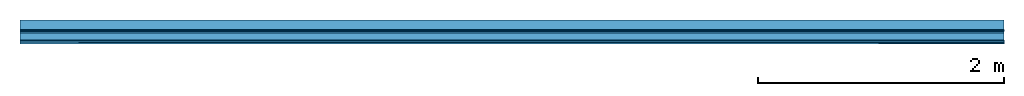
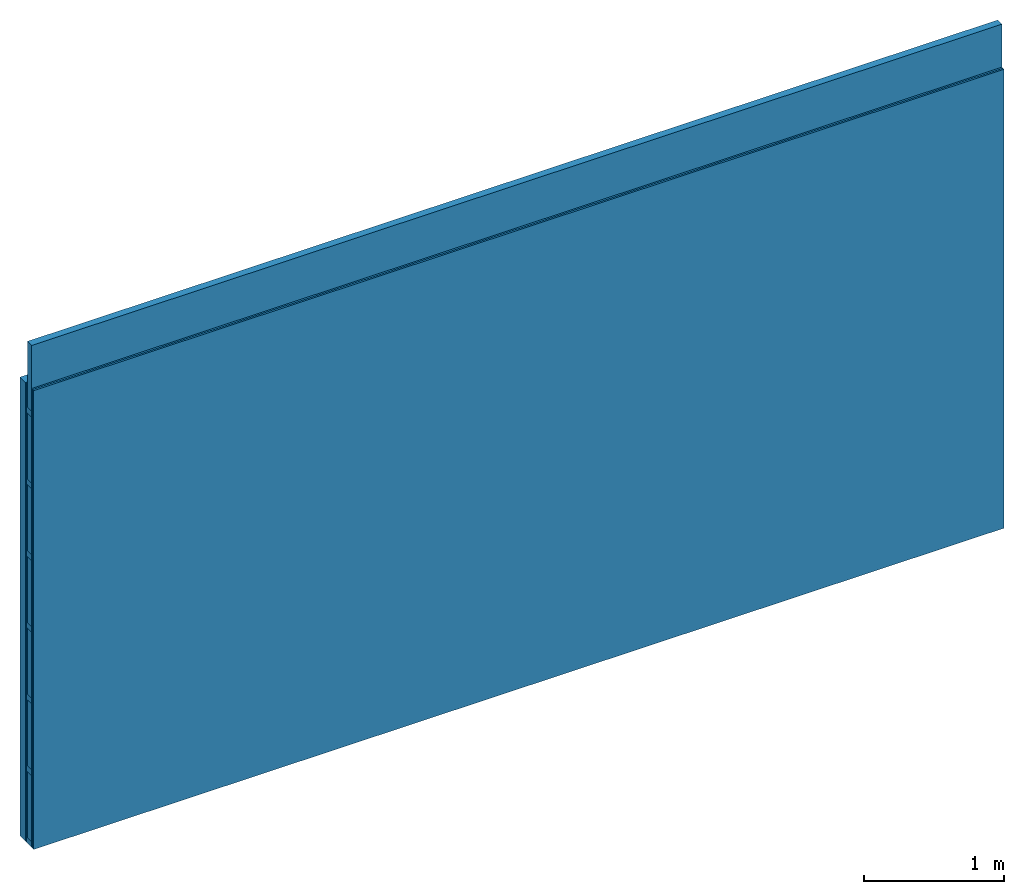
# One storey: 3 members, 3 plates, 1 element without a shape of its own.
"""IFC4 building model written with IfcOpenShell, lengths in metres."""

from ifc_helpers import new_model, si_unit, derived_unit, direction, frame, frame_2d, origin, place, context, project, spatial, rectangle, extrude, material, layer, layer_set, type_object, element, aggregate, save


model = new_model("IFC4")

# Units and contexts
plan_context = context("Plan", 3, precision=1e-05, world=origin(), true_north=direction((0.0, 1.0)))
model_context = context("Model", 3, precision=1e-05, world=origin(), true_north=direction((0.0, 1.0)))
ifc_project = project(units=[si_unit("LENGTHUNIT", "METRE"), derived_unit("SOUNDPRESSUREUNIT", [(si_unit("PRESSUREUNIT", "PASCAL", prefix="MICRO"), 0)]), si_unit("ENERGYUNIT", "JOULE", prefix="MEGA"), si_unit("MASSUNIT", "GRAM", prefix="KILO"), derived_unit("THERMALTRANSMITTANCEUNIT", [(si_unit("POWERUNIT", "WATT"), 1), (si_unit("AREAUNIT", "SQUARE_METRE"), -1), (si_unit("THERMODYNAMICTEMPERATUREUNIT", "KELVIN"), -1)]), derived_unit("AREADENSITYUNIT", [(si_unit("MASSUNIT", "GRAM", prefix="KILO"), 1), (si_unit("AREAUNIT", "SQUARE_METRE"), -1)]), derived_unit("USERDEFINED", [(si_unit("ENERGYUNIT", "JOULE", prefix="MEGA"), 1), (si_unit("AREAUNIT", "SQUARE_METRE"), -1)])], contexts=[plan_context, model_context])

# Site, building, storey
site = spatial("IfcSite", under=ifc_project)
building_placement = place(None, origin())
building = spatial("IfcBuilding", under=site, at=building_placement)
storey_placement = place(building_placement, origin())
storey = spatial("IfcBuildingStorey", under=building, at=storey_placement)

# Wall, members, plates
ifc_layer_1 = layer(None, 0.08, Name="Support")
ifc_material_1 = material(Name="Air")
ifc_layer_2 = layer(ifc_material_1, 0.01, Name="Coupling")
ifc_layer_3 = layer(None, 0.075, Name="Battens / profiles")
ifc_material_2 = material(Category="03.007")
ifc_layer_4 = layer(ifc_material_2, 0.015, Name="Covering 1st layer")
ifc_layer_5 = layer(ifc_material_2, 0.015, Name="Covering 2nd layer")
ifc_material_3 = material(Name="Glued joints")
ifc_layer_6 = layer(ifc_material_3, 0.0, Name="Surface")
ifc_layer_set = layer_set([ifc_layer_1, ifc_layer_2, ifc_layer_3, ifc_layer_4, ifc_layer_5, ifc_layer_6])
wall_type = type_object("IfcWallType", Name="C0107", PredefinedType="NOTDEFINED", material=ifc_layer_set)
wall_placement = place(None, frame((0.0, 0.0, 0.0), z_axis=(0.0, -1.0, 0.0), x_axis=(1.0, 0.0, 0.0)))
wall = element("IfcWall", 1, at=wall_placement, inside=storey, type_object=wall_type, material=ifc_layer_set, Name="Wall #1")
ifc_material_4 = material()
member_1_placement = place(wall_placement, origin())
member_1 = element("IfcMember", 2, at=member_1_placement, material=ifc_material_4, Name="Support", context=plan_context, shape_type="SweptSolid", body=[
    extrude(rectangle(XDim=1.0, YDim=0.08, at=frame_2d((0.5, 0.04), x_axis=(1.0, 0.0))), frame((0.0, 4.0, 0.0), z_axis=(0.0, -1.0, 0.0), x_axis=(1.0, 0.0, 0.0)), (0.0, 0.0, 1.0), 4.0),
    extrude(rectangle(XDim=1.0, YDim=0.08, at=frame_2d((0.5, 0.04), x_axis=(1.0, 0.0))), frame((1.0, 4.0, 0.0), z_axis=(0.0, -1.0, 0.0), x_axis=(1.0, 0.0, 0.0)), (0.0, 0.0, 1.0), 4.0),
    extrude(rectangle(XDim=1.0, YDim=0.08, at=frame_2d((0.5, 0.04), x_axis=(1.0, 0.0))), frame((2.0, 4.0, 0.0), z_axis=(0.0, -1.0, 0.0), x_axis=(1.0, 0.0, 0.0)), (0.0, 0.0, 1.0), 4.0),
    extrude(rectangle(XDim=1.0, YDim=0.08, at=frame_2d((0.5, 0.04), x_axis=(1.0, 0.0))), frame((3.0, 4.0, 0.0), z_axis=(0.0, -1.0, 0.0), x_axis=(1.0, 0.0, 0.0)), (0.0, 0.0, 1.0), 4.0),
    extrude(rectangle(XDim=1.0, YDim=0.08, at=frame_2d((0.5, 0.04), x_axis=(1.0, 0.0))), frame((4.0, 4.0, 0.0), z_axis=(0.0, -1.0, 0.0), x_axis=(1.0, 0.0, 0.0)), (0.0, 0.0, 1.0), 4.0),
    extrude(rectangle(XDim=1.0, YDim=0.08, at=frame_2d((0.5, 0.04), x_axis=(1.0, 0.0))), frame((5.0, 4.0, 0.0), z_axis=(0.0, -1.0, 0.0), x_axis=(1.0, 0.0, 0.0)), (0.0, 0.0, 1.0), 4.0),
    extrude(rectangle(XDim=1.0, YDim=0.08, at=frame_2d((0.5, 0.04), x_axis=(1.0, 0.0))), frame((6.0, 4.0, 0.0), z_axis=(0.0, -1.0, 0.0), x_axis=(1.0, 0.0, 0.0)), (0.0, 0.0, 1.0), 4.0),
    extrude(rectangle(XDim=1.0, YDim=0.08, at=frame_2d((0.5, 0.04), x_axis=(1.0, 0.0))), frame((7.0, 4.0, 0.0), z_axis=(0.0, -1.0, 0.0), x_axis=(1.0, 0.0, 0.0)), (0.0, 0.0, 1.0), 4.0),
])
ifc_material_5 = material()
member_2_placement = place(wall_placement, origin())
member_2 = element("IfcMember", 3, at=member_2_placement, material=ifc_material_5, Name="Battens / profiles", context=plan_context, shape_type="SweptSolid", body=[
    extrude(rectangle(XDim=0.05, YDim=0.075, at=frame_2d((0.025, 0.0375), x_axis=(1.0, 0.0))), frame((0.0, 0.0, 0.09), z_axis=(1.0, 0.0, 0.0), x_axis=(0.0, 1.0, 0.0)), (0.0, 0.0, 1.0), 8.0),
    extrude(rectangle(XDim=0.05, YDim=0.075, at=frame_2d((0.025, 0.0375), x_axis=(1.0, 0.0))), frame((0.0, 0.625, 0.09), z_axis=(1.0, 0.0, 0.0), x_axis=(0.0, 1.0, 0.0)), (0.0, 0.0, 1.0), 8.0),
    extrude(rectangle(XDim=0.05, YDim=0.075, at=frame_2d((0.025, 0.0375), x_axis=(1.0, 0.0))), frame((0.0, 1.25, 0.09), z_axis=(1.0, 0.0, 0.0), x_axis=(0.0, 1.0, 0.0)), (0.0, 0.0, 1.0), 8.0),
    extrude(rectangle(XDim=0.05, YDim=0.075, at=frame_2d((0.025, 0.0375), x_axis=(1.0, 0.0))), frame((0.0, 1.875, 0.09), z_axis=(1.0, 0.0, 0.0), x_axis=(0.0, 1.0, 0.0)), (0.0, 0.0, 1.0), 8.0),
    extrude(rectangle(XDim=0.05, YDim=0.075, at=frame_2d((0.025, 0.0375), x_axis=(1.0, 0.0))), frame((0.0, 2.5, 0.09), z_axis=(1.0, 0.0, 0.0), x_axis=(0.0, 1.0, 0.0)), (0.0, 0.0, 1.0), 8.0),
    extrude(rectangle(XDim=0.05, YDim=0.075, at=frame_2d((0.025, 0.0375), x_axis=(1.0, 0.0))), frame((0.0, 3.125, 0.09), z_axis=(1.0, 0.0, 0.0), x_axis=(0.0, 1.0, 0.0)), (0.0, 0.0, 1.0), 8.0),
    extrude(rectangle(XDim=0.05, YDim=0.075, at=frame_2d((0.025, 0.0375), x_axis=(1.0, 0.0))), frame((0.0, 3.75, 0.09), z_axis=(1.0, 0.0, 0.0), x_axis=(0.0, 1.0, 0.0)), (0.0, 0.0, 1.0), 8.0),
])
ifc_material_6 = material()
member_3_placement = place(wall_placement, origin())
member_3 = element("IfcMember", 4, at=member_3_placement, material=ifc_material_6, Name="Cavity", context=plan_context, shape_type="SweptSolid", body=[
    extrude(rectangle(XDim=0.575, YDim=0.06, at=frame_2d((0.2875, 0.03), x_axis=(1.0, 0.0))), frame((0.0, 0.05, 0.105), z_axis=(1.0, 0.0, 0.0), x_axis=(0.0, 1.0, 0.0)), (0.0, 0.0, 1.0), 8.0),
    extrude(rectangle(XDim=0.575, YDim=0.06, at=frame_2d((0.2875, 0.03), x_axis=(1.0, 0.0))), frame((0.0, 0.675, 0.105), z_axis=(1.0, 0.0, 0.0), x_axis=(0.0, 1.0, 0.0)), (0.0, 0.0, 1.0), 8.0),
    extrude(rectangle(XDim=0.575, YDim=0.06, at=frame_2d((0.2875, 0.03), x_axis=(1.0, 0.0))), frame((0.0, 1.3, 0.105), z_axis=(1.0, 0.0, 0.0), x_axis=(0.0, 1.0, 0.0)), (0.0, 0.0, 1.0), 8.0),
    extrude(rectangle(XDim=0.575, YDim=0.06, at=frame_2d((0.2875, 0.03), x_axis=(1.0, 0.0))), frame((0.0, 1.925, 0.105), z_axis=(1.0, 0.0, 0.0), x_axis=(0.0, 1.0, 0.0)), (0.0, 0.0, 1.0), 8.0),
    extrude(rectangle(XDim=0.575, YDim=0.06, at=frame_2d((0.2875, 0.03), x_axis=(1.0, 0.0))), frame((0.0, 2.55, 0.105), z_axis=(1.0, 0.0, 0.0), x_axis=(0.0, 1.0, 0.0)), (0.0, 0.0, 1.0), 8.0),
    extrude(rectangle(XDim=0.575, YDim=0.06, at=frame_2d((0.2875, 0.03), x_axis=(1.0, 0.0))), frame((0.0, 3.175, 0.105), z_axis=(1.0, 0.0, 0.0), x_axis=(0.0, 1.0, 0.0)), (0.0, 0.0, 1.0), 8.0),
    extrude(rectangle(XDim=0.575, YDim=0.06, at=frame_2d((0.2875, 0.03), x_axis=(1.0, 0.0))), frame((0.0, 3.8, 0.105), z_axis=(1.0, 0.0, 0.0), x_axis=(0.0, 1.0, 0.0)), (0.0, 0.0, 1.0), 8.0),
])
plate_1_placement = place(wall_placement, origin())
plate_1 = element("IfcPlate", 5, at=plate_1_placement, material=ifc_material_1, Name="Coupling", context=plan_context, shape_type="SweptSolid", body=[
    extrude(rectangle(XDim=8.0, YDim=4.0, at=frame_2d((4.0, 2.0), x_axis=(1.0, 0.0))), frame((0.0, 0.0, 0.08), z_axis=(0.0, 0.0, 1.0), x_axis=(1.0, 0.0, 0.0)), (0.0, 0.0, 1.0), 0.01),
])
plate_2_placement = place(wall_placement, origin())
plate_2 = element("IfcPlate", 6, at=plate_2_placement, material=ifc_material_2, Name="Covering 1st layer", context=plan_context, shape_type="SweptSolid", body=[
    extrude(rectangle(XDim=8.0, YDim=4.0, at=frame_2d((4.0, 2.0), x_axis=(1.0, 0.0))), frame((0.0, 0.0, 0.165), z_axis=(0.0, 0.0, 1.0), x_axis=(1.0, 0.0, 0.0)), (0.0, 0.0, 1.0), 0.015),
])
plate_3_placement = place(wall_placement, origin())
plate_3 = element("IfcPlate", 7, at=plate_3_placement, material=ifc_material_2, Name="Covering 2nd layer", context=plan_context, shape_type="SweptSolid", body=[
    extrude(rectangle(XDim=8.0, YDim=4.0, at=frame_2d((4.0, 2.0), x_axis=(1.0, 0.0))), frame((0.0, 0.0, 0.18), z_axis=(0.0, 0.0, 1.0), x_axis=(1.0, 0.0, 0.0)), (0.0, 0.0, 1.0), 0.015),
])
aggregate(wall, [member_1, plate_1, member_2, member_3, plate_2, plate_3])

save(model, "model.ifc")
